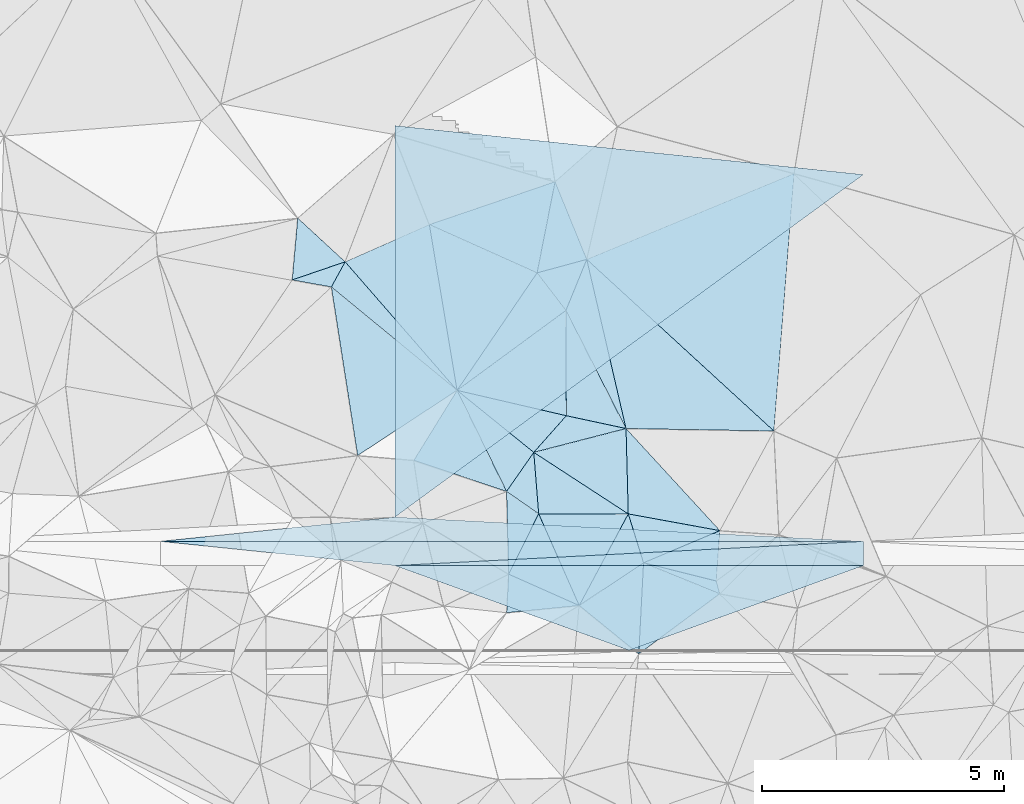
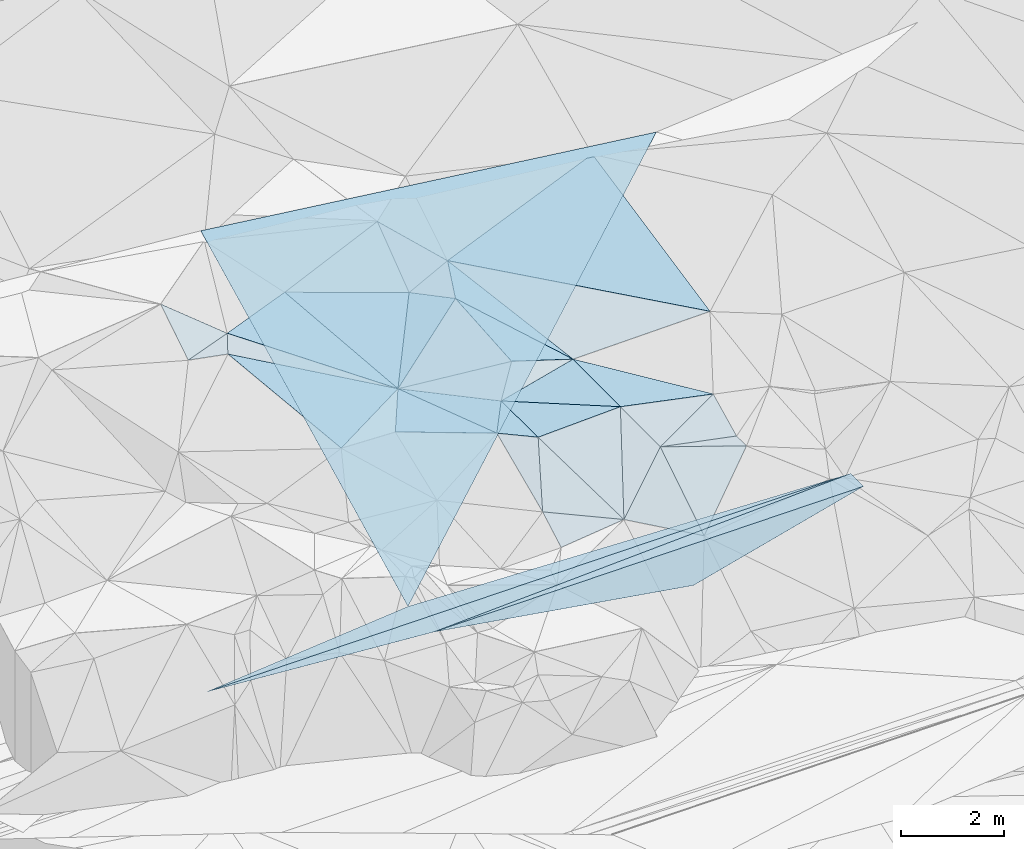
# One storey, part 69 of 275: 48 plates.
"""IFC2X3 building model written with IfcOpenShell, lengths in millimetres."""

from ifc_helpers import new_model, si_unit, frame, origin_with_axes, place, context, subcontext, project, spatial, polyline, outline, extrude, material, type_object, element, save


model = new_model("IFC2X3")

# Units and contexts
model_context = context("Model", 3, precision=1e-05, world=origin_with_axes())
body_context = subcontext(model_context, "Body", "Model", "MODEL_VIEW")
ifc_project = project(units=[si_unit("LENGTHUNIT", "METRE", prefix="MILLI"), si_unit("AREAUNIT", "SQUARE_METRE"), si_unit("VOLUMEUNIT", "CUBIC_METRE"), si_unit("MASSUNIT", "GRAM", prefix="KILO"), si_unit("TIMEUNIT", "SECOND"), si_unit("PLANEANGLEUNIT", "RADIAN"), si_unit("SOLIDANGLEUNIT", "STERADIAN"), si_unit("THERMODYNAMICTEMPERATUREUNIT", "DEGREE_CELSIUS"), si_unit("LUMINOUSINTENSITYUNIT", "LUMEN")], contexts=[model_context])

# Site, building, storey
site_placement = place(None, origin_with_axes())
site = spatial("IfcSite", under=ifc_project, at=site_placement, CompositionType="ELEMENT")
building_placement = place(site_placement, origin_with_axes())
building = spatial("IfcBuilding", under=site, at=building_placement, Name="Undefined", CompositionType="ELEMENT")
storey_placement = place(building_placement, origin_with_axes())
storey = spatial("IfcBuildingStorey", under=building, at=storey_placement, Name="Undefined", CompositionType="ELEMENT", Elevation=0.0)

# Plates
ifc_material = material()
plate_type_1 = type_object("IfcPlateType", PredefinedType="NOTDEFINED")
plate_1_placement = place(storey_placement, frame((-129444.335760061, 69294.3090173792, 48443.6810089496), z_axis=(0.00832550512650313, -4.76525014343269e-07, -0.999965342381505), x_axis=(0.998627967402267, -0.0517015939711349, 0.00831431914595258)))
element("IfcPlate", 1, at=plate_1_placement, inside=storey, type_object=plate_type_1, material=ifc_material, Name="00_PR", context=body_context, shape_type="SweptSolid", body=[
    extrude(outline(polyline([(0.0, 0.0), (9681.6103515625, -4.99348971061409e-08), (-4802.072265625, 748.999816894531), (0.0, 0.0)])), frame((-8.85201319254618e-08, 2.18876761149539e-07, -0.5000001331573), z_axis=(0.0, 0.0, 1.0), x_axis=(1.0, 0.0, 0.0)), (0.0, 0.0, 1.0), 1.0),
])
plate_2_placement = place(storey_placement, frame((-119776.008774443, 68793.7543278347, 48524.17701052), z_axis=(0.00832550512650313, -4.76525014343269e-07, -0.999965342381505), x_axis=(-5.72939716861899e-05, -0.9999999983587, -3.69036567042244e-11)))
element("IfcPlate", 2, at=plate_2_placement, inside=storey, type_object=plate_type_1, material=ifc_material, Name="00_PR", context=body_context, shape_type="SweptSolid", body=[
    extrude(outline(polyline([(0.0, 0.0), (500.0, 8.00355337560177e-10), (499.999267578125, 9668.6904296875), (0.0, 0.0)])), frame((-8.85201319254618e-08, 2.18876761149539e-07, -0.5000001331573), z_axis=(0.0, 0.0, 1.0), x_axis=(1.0, 0.0, 0.0)), (0.0, 0.0, 1.0), 1.0),
])
plate_3_placement = place(storey_placement, frame((-129444.393052582, 68294.3090073163, 48443.6810090413), z_axis=(0.00832550512650313, -4.76525014343269e-07, -0.999965342381505), x_axis=(-0.994653635901684, 0.102934762919728, -0.0082812541453832)))
element("IfcPlate", 3, at=plate_3_placement, inside=storey, type_object=plate_type_1, material=ifc_material, Name="00_PR", context=body_context, shape_type="SweptSolid", body=[
    extrude(outline(polyline([(0.0, 0.0), (4860.13330078125, -1.09284883365035e-08), (-9565.9501953125, 1492.03967285156), (0.0, 0.0)])), frame((-8.85201319254618e-08, 2.18876761149539e-07, -0.5000001331573), z_axis=(0.0, 0.0, 1.0), x_axis=(1.0, 0.0, 0.0)), (0.0, 0.0, 1.0), 1.0),
])
plate_4_placement = place(storey_placement, frame((-129444.335760061, 69294.3090173792, 48443.6810089496), z_axis=(0.00832550512650313, -4.76525014343269e-07, -0.999965342381505), x_axis=(0.998627967402267, -0.0517015939711349, 0.00831431914595258)))
element("IfcPlate", 4, at=plate_4_placement, inside=storey, type_object=plate_type_1, material=ifc_material, Name="00_PR", context=body_context, shape_type="SweptSolid", body=[
    extrude(outline(polyline([(0.0, 0.0), (9681.6103515625, -4.99348971061409e-08), (-4802.072265625, 748.999816894531), (0.0, 0.0)])), frame((-8.85201319254618e-08, 2.18876761149539e-07, -0.5000001331573), z_axis=(0.0, 0.0, 1.0), x_axis=(1.0, 0.0, 0.0)), (0.0, 0.0, 1.0), 1.0),
])
plate_5_placement = place(storey_placement, frame((-119776.008774443, 68793.7543278347, 48524.17701052), z_axis=(0.00832550512650313, -4.76525014343269e-07, -0.999965342381505), x_axis=(-5.72939716861899e-05, -0.9999999983587, -3.69036567042244e-11)))
element("IfcPlate", 5, at=plate_5_placement, inside=storey, type_object=plate_type_1, material=ifc_material, Name="00_PR", context=body_context, shape_type="SweptSolid", body=[
    extrude(outline(polyline([(0.0, 0.0), (500.0, 8.00355337560177e-10), (499.999267578125, 9668.6904296875), (0.0, 0.0)])), frame((-8.85201319254618e-08, 2.18876761149539e-07, -0.5000001331573), z_axis=(0.0, 0.0, 1.0), x_axis=(1.0, 0.0, 0.0)), (0.0, 0.0, 1.0), 1.0),
])
plate_6_placement = place(storey_placement, frame((-129444.393052582, 68294.3090073163, 48443.6810090413), z_axis=(0.00832550512650313, -4.76525014343269e-07, -0.999965342381505), x_axis=(-0.994653635901684, 0.102934762919728, -0.0082812541453832)))
element("IfcPlate", 6, at=plate_6_placement, inside=storey, type_object=plate_type_1, material=ifc_material, Name="00_PR", context=body_context, shape_type="SweptSolid", body=[
    extrude(outline(polyline([(0.0, 0.0), (4860.13330078125, -1.09284883365035e-08), (-9565.9501953125, 1492.03967285156), (0.0, 0.0)])), frame((-8.85201319254618e-08, 2.18876761149539e-07, -0.5000001331573), z_axis=(0.0, 0.0, 1.0), x_axis=(1.0, 0.0, 0.0)), (0.0, 0.0, 1.0), 1.0),
])
plate_7_placement = place(storey_placement, frame((-129444.335760061, 69294.3090173792, 48443.6810089496), z_axis=(0.00832550512650313, -4.76525014343269e-07, -0.999965342381505), x_axis=(0.998627967402267, -0.0517015939711349, 0.00831431914595258)))
element("IfcPlate", 7, at=plate_7_placement, inside=storey, type_object=plate_type_1, material=ifc_material, Name="00_PR", context=body_context, shape_type="SweptSolid", body=[
    extrude(outline(polyline([(0.0, 0.0), (9681.6103515625, -4.99348971061409e-08), (-4802.072265625, 748.999816894531), (0.0, 0.0)])), frame((-8.85201319254618e-08, 2.18876761149539e-07, -0.5000001331573), z_axis=(0.0, 0.0, 1.0), x_axis=(1.0, 0.0, 0.0)), (0.0, 0.0, 1.0), 1.0),
])
plate_8_placement = place(storey_placement, frame((-119776.008774443, 68793.7543278347, 48524.17701052), z_axis=(0.00832550512650313, -4.76525014343269e-07, -0.999965342381505), x_axis=(-5.72939716861899e-05, -0.9999999983587, -3.69036567042244e-11)))
element("IfcPlate", 8, at=plate_8_placement, inside=storey, type_object=plate_type_1, material=ifc_material, Name="00_PR", context=body_context, shape_type="SweptSolid", body=[
    extrude(outline(polyline([(0.0, 0.0), (500.0, 8.00355337560177e-10), (499.999267578125, 9668.6904296875), (0.0, 0.0)])), frame((-8.85201319254618e-08, 2.18876761149539e-07, -0.5000001331573), z_axis=(0.0, 0.0, 1.0), x_axis=(1.0, 0.0, 0.0)), (0.0, 0.0, 1.0), 1.0),
])
plate_9_placement = place(storey_placement, frame((-129444.393052582, 68294.3090073163, 48443.6810090413), z_axis=(0.00832550512650313, -4.76525014343269e-07, -0.999965342381505), x_axis=(-0.994653635901684, 0.102934762919728, -0.0082812541453832)))
element("IfcPlate", 9, at=plate_9_placement, inside=storey, type_object=plate_type_1, material=ifc_material, Name="00_PR", context=body_context, shape_type="SweptSolid", body=[
    extrude(outline(polyline([(0.0, 0.0), (4860.13330078125, -1.09284883365035e-08), (-9565.9501953125, 1492.03967285156), (0.0, 0.0)])), frame((-8.85201319254618e-08, 2.18876761149539e-07, -0.5000001331573), z_axis=(0.0, 0.0, 1.0), x_axis=(1.0, 0.0, 0.0)), (0.0, 0.0, 1.0), 1.0),
])
plate_type_2 = type_object("IfcPlateType", PredefinedType="NOTDEFINED")
plate_10_placement = place(storey_placement, frame((-124312.937117291, 68351.7391393524, 51019.5248388097), z_axis=(0.0515360907976266, 0.307029882947136, -0.950303468541901), x_axis=(0.907700275136061, 0.382399613268588, 0.172773685177903)))
element("IfcPlate", 10, at=plate_10_placement, inside=storey, type_object=plate_type_2, material=ifc_material, Name="00", context=body_context, shape_type="SweptSolid", body=[
    extrude(outline(polyline([(0.0, 0.0), (1736.37548828125, 5.82076609134674e-10), (1210.970703125, 962.314819335938), (0.0, 0.0)])), frame((-8.85201319254618e-08, 2.18876761149539e-07, -0.5000001331573), z_axis=(0.0, 0.0, 1.0), x_axis=(1.0, 0.0, 0.0)), (0.0, 0.0, 1.0), 1.0),
])
plate_type_3 = type_object("IfcPlateType", PredefinedType="NOTDEFINED")
plate_11_placement = place(storey_placement, frame((-126577.770346857, 70630.4646512945, 51519.5032296527), z_axis=(0.0431356535289658, 0.105349458426082, -0.993499273781295), x_axis=(0.83776809942243, -0.545603499068623, -0.0214810007728772)))
element("IfcPlate", 11, at=plate_11_placement, inside=storey, type_object=plate_type_3, material=ifc_material, Name="00", context=body_context, shape_type="SweptSolid", body=[
    extrude(outline(polyline([(0.0, 0.0), (2327.63818359375, -1.15605871542357e-08), (778.944030761719, 1013.18615722656), (0.0, 0.0)])), frame((-8.85201319254618e-08, 2.18876761149539e-07, -0.5000001331573), z_axis=(0.0, 0.0, 1.0), x_axis=(1.0, 0.0, 0.0)), (0.0, 0.0, 1.0), 1.0),
])
plate_type_4 = type_object("IfcPlateType", PredefinedType="NOTDEFINED")
plate_12_placement = place(storey_placement, frame((-124627.769831021, 69360.6483166408, 51469.5434608035), z_axis=(0.00196016810434817, 0.407870757378614, -0.91303756933458), x_axis=(0.980790077208936, -0.178878605876782, -0.0778027557871022)))
element("IfcPlate", 12, at=plate_12_placement, inside=storey, type_object=plate_type_4, material=ifc_material, Name="00", context=body_context, shape_type="SweptSolid", body=[
    extrude(outline(polyline([(0.0, 0.0), (1927.95227050781, -1.5352270565927e-08), (524.234985351563, 1022.04583740234), (0.0, 0.0)])), frame((-8.85201319254618e-08, 2.18876761149539e-07, -0.5000001331573), z_axis=(0.0, 0.0, 1.0), x_axis=(1.0, 0.0, 0.0)), (0.0, 0.0, 1.0), 1.0),
])
plate_type_5 = type_object("IfcPlateType", PredefinedType="NOTDEFINED")
plate_13_placement = place(storey_placement, frame((-124674.143238548, 71122.2047011062, 51549.5079593626), z_axis=(-0.158348949246532, 0.0809064240033333, -0.98406288458996), x_axis=(-0.963176777696257, 0.206672142717296, 0.171979999800261)))
element("IfcPlate", 13, at=plate_13_placement, inside=storey, type_object=plate_type_5, material=ifc_material, Name="00", context=body_context, shape_type="SweptSolid", body=[
    extrude(outline(polyline([(0.0, 0.0), (1279.21850585938, -7.45058059692383e-09), (1767.64172363281, 2123.87451171875), (0.0, 0.0)])), frame((-8.85201319254618e-08, 2.18876761149539e-07, -0.5000001331573), z_axis=(0.0, 0.0, 1.0), x_axis=(1.0, 0.0, 0.0)), (0.0, 0.0, 1.0), 1.0),
])
plate_type_6 = type_object("IfcPlateType", PredefinedType="NOTDEFINED")
plate_14_placement = place(storey_placement, frame((-124674.096315958, 71122.2290468685, 51549.5052579462), z_axis=(-0.0645017647531431, 0.129600696756393, -0.989466109446902), x_axis=(-0.449131033183579, 0.88166109684592, 0.144758506969021)))
element("IfcPlate", 14, at=plate_14_placement, inside=storey, type_object=plate_type_6, material=ifc_material, Name="00", context=body_context, shape_type="SweptSolid", body=[
    extrude(outline(polyline([(0.0, 0.0), (2763.22265625, -2.52039171755314e-08), (3515.13452148438, 862.107055664063), (0.0, 0.0)])), frame((-8.85201319254618e-08, 2.18876761149539e-07, -0.5000001331573), z_axis=(0.0, 0.0, 1.0), x_axis=(1.0, 0.0, 0.0)), (0.0, 0.0, 1.0), 1.0),
])
plate_type_7 = type_object("IfcPlateType", PredefinedType="NOTDEFINED")
plate_15_placement = place(storey_placement, frame((-127139.727185454, 69824.5325130001, 51439.5665744181), z_axis=(0.239030809457038, 0.437609843361658, -0.866811338829447), x_axis=(0.819368744523016, -0.569928124129053, -0.0617802057743058)))
element("IfcPlate", 15, at=plate_15_placement, inside=storey, type_object=plate_type_7, material=ifc_material, Name="00", context=body_context, shape_type="SweptSolid", body=[
    extrude(outline(polyline([(0.0, 0.0), (809.320678710938, 2.80488166026771e-09), (1062.24890136719, 1585.25305175781), (0.0, 0.0)])), frame((-8.85201319254618e-08, 2.18876761149539e-07, -0.5000001331573), z_axis=(0.0, 0.0, 1.0), x_axis=(1.0, 0.0, 0.0)), (0.0, 0.0, 1.0), 1.0),
])
plate_type_8 = type_object("IfcPlateType", PredefinedType="NOTDEFINED")
for number, where, z_axis, x_axis, name in (
    (16, (-129444.39318017, 68294.1877470874, 48443.6959361818), (0.00806306952558709, -0.242528174049018, -0.970110855367713), (0.999965340787191, -5.73519775278889e-05, 0.0083254990906575), "00_PR"),
    (17, (-129444.39318017, 68294.1877470874, 48443.6959361818), (0.00806306952558709, -0.242528174049018, -0.970110855367713), (0.999965340787191, -5.73519775278889e-05, 0.0083254990906575), "00_PR"),
    (18, (-129444.39318017, 68294.1877470874, 48443.6959361818), (0.00806306952558709, -0.242528174049018, -0.970110855367713), (0.999965340787191, -5.73519775278889e-05, 0.0083254990906575), "00_PR"),
):
    element("IfcPlate", number, at=place(storey_placement, frame(where, z_axis=z_axis, x_axis=x_axis)), inside=storey, type_object=plate_type_8, material=ifc_material, Name=name, context=body_context, shape_type="SweptSolid", body=[
        extrude(outline(polyline([(0.0, 0.0), (9668.6904296875, -3.96539689972997e-09), (4837.9873046875, 1803.85485839844), (0.0, 0.0)])), frame((-8.85201319254618e-08, 2.18876761149539e-07, -0.5000001331573), z_axis=(0.0, 0.0, 1.0), x_axis=(1.0, 0.0, 0.0)), (0.0, 0.0, 1.0), 1.0),
    ])
plate_type_9 = type_object("IfcPlateType", PredefinedType="NOTDEFINED")
for number, where, z_axis, x_axis, name in (
    (19, (-129444.336182528, 69294.53261692, 48443.733790464), (0.00747221277555471, 0.447200796920443, -0.894402377719311), (5.12609174268665e-05, 0.894427213806252, 0.447213546949446), "00_PR"),
    (20, (-129444.336182528, 69294.53261692, 48443.733790464), (0.00747221277555471, 0.447200796920443, -0.894402377719311), (5.12609174268665e-05, 0.894427213806252, 0.447213546949446), "00_PR"),
    (21, (-129444.336182528, 69294.53261692, 48443.733790464), (0.00747221277555471, 0.447200796920443, -0.894402377719311), (5.12609174268665e-05, 0.894427213806252, 0.447213546949446), "00_PR"),
):
    element("IfcPlate", number, at=place(storey_placement, frame(where, z_axis=z_axis, x_axis=x_axis)), inside=storey, type_object=plate_type_9, material=ifc_material, Name=name, context=body_context, shape_type="SweptSolid", body=[
        extrude(outline(polyline([(0.0, 0.0), (9030.6259765625, 4.51982486993074e-08), (7938.47216796875, 9668.623046875), (0.0, 0.0)])), frame((-8.85201319254618e-08, 2.18876761149539e-07, -0.5000001331573), z_axis=(0.0, 0.0, 1.0), x_axis=(1.0, 0.0, 0.0)), (0.0, 0.0, 1.0), 1.0),
    ])
plate_type_10 = type_object("IfcPlateType", PredefinedType="NOTDEFINED")
plate_16_placement = place(storey_placement, frame((-128160.253068707, 71909.8952778772, 51589.5072815032), z_axis=(-0.0291699102488049, 0.167773082117906, -0.985393986815799), x_axis=(-0.765830912353817, 0.629785394063295, 0.129897540807591)))
element("IfcPlate", 22, at=plate_16_placement, inside=storey, type_object=plate_type_10, material=ifc_material, Name="00", context=body_context, shape_type="SweptSolid", body=[
    extrude(outline(polyline([(0.0, 0.0), (3387.28515625, -1.40862539410591e-08), (3506.99755859375, 585.293884277344), (0.0, 0.0)])), frame((-8.85201319254618e-08, 2.18876761149539e-07, -0.5000001331573), z_axis=(0.0, 0.0, 1.0), x_axis=(1.0, 0.0, 0.0)), (0.0, 0.0, 1.0), 1.0),
])
plate_type_11 = type_object("IfcPlateType", PredefinedType="NOTDEFINED")
plate_17_placement = place(storey_placement, frame((-125906.11466732, 71386.6474831464, 51769.5150823467), z_axis=(0.125918911407506, 0.208806652836142, -0.969816585484758), x_axis=(-0.644681218496998, -0.725808764752047, -0.239974505992477)))
element("IfcPlate", 23, at=plate_17_placement, inside=storey, type_object=plate_type_11, material=ifc_material, Name="00", context=body_context, shape_type="SweptSolid", body=[
    extrude(outline(polyline([(0.0, 0.0), (1041.77734375, -4.86033968627453e-09), (1116.55334472656, 2034.77478027344), (0.0, 0.0)])), frame((-8.85201319254618e-08, 2.18876761149539e-07, -0.5000001331573), z_axis=(0.0, 0.0, 1.0), x_axis=(1.0, 0.0, 0.0)), (0.0, 0.0, 1.0), 1.0),
])
plate_type_12 = type_object("IfcPlateType", PredefinedType="NOTDEFINED")
plate_18_placement = place(storey_placement, frame((-124674.099632621, 71122.1859397391, 51549.5017295349), z_axis=(-0.0711384885321428, 0.0433829312007016, -0.996522572112543), x_axis=(0.674719800359606, -0.733713797086432, -0.0801077709570257)))
element("IfcPlate", 24, at=plate_18_placement, inside=storey, type_object=plate_type_12, material=ifc_material, Name="00", context=body_context, shape_type="SweptSolid", body=[
    extrude(outline(polyline([(0.0, 0.0), (2871.13208007813, -8.49831849336624e-09), (1330.24182128906, 1158.73071289063), (0.0, 0.0)])), frame((-8.85201319254618e-08, 2.18876761149539e-07, -0.5000001331573), z_axis=(0.0, 0.0, 1.0), x_axis=(1.0, 0.0, 0.0)), (0.0, 0.0, 1.0), 1.0),
])
plate_type_13 = type_object("IfcPlateType", PredefinedType="NOTDEFINED")
plate_19_placement = place(storey_placement, frame((-126509.590636603, 74334.3753728813, 51829.511725589), z_axis=(0.0171571075948877, 0.214691930279505, -0.97653110996621), x_axis=(-0.910029584673822, 0.407939743608207, 0.0736974938736797)))
element("IfcPlate", 25, at=plate_19_placement, inside=storey, type_object=plate_type_13, material=ifc_material, Name="00", context=body_context, shape_type="SweptSolid", body=[
    extrude(outline(polyline([(0.0, 0.0), (2442.41674804688, -6.71934685669839e-09), (460.322723388672, 1907.72192382813), (0.0, 0.0)])), frame((-8.85201319254618e-08, 2.18876761149539e-07, -0.5000001331573), z_axis=(0.0, 0.0, 1.0), x_axis=(1.0, 0.0, 0.0)), (0.0, 0.0, 1.0), 1.0),
])
plate_type_14 = type_object("IfcPlateType", PredefinedType="NOTDEFINED")
plate_20_placement = place(storey_placement, frame((-125484.459065814, 74612.4986336358, 52059.5117680325), z_axis=(0.215310766088622, 0.0139528963210471, -0.976445897472351), x_axis=(-0.376371330773425, -0.921465191023686, -0.0961588430854013)))
element("IfcPlate", 26, at=plate_20_placement, inside=storey, type_object=plate_type_14, material=ifc_material, Name="00", context=body_context, shape_type="SweptSolid", body=[
    extrude(outline(polyline([(0.0, 0.0), (1143.94055175781, -6.19911588728428e-09), (664.282775878906, 860.074645996094), (0.0, 0.0)])), frame((-8.85201319254618e-08, 2.18876761149539e-07, -0.5000001331573), z_axis=(0.0, 0.0, 1.0), x_axis=(1.0, 0.0, 0.0)), (0.0, 0.0, 1.0), 1.0),
])
plate_type_15 = type_object("IfcPlateType", PredefinedType="NOTDEFINED")
plate_21_placement = place(storey_placement, frame((-128732.284714729, 75330.6855391924, 52009.5036333081), z_axis=(-0.0278441221793931, 0.117227145086736, -0.992714712953763), x_axis=(0.910029584672226, -0.407939743615816, -0.0736974938512678)))
element("IfcPlate", 27, at=plate_21_placement, inside=storey, type_object=plate_type_15, material=ifc_material, Name="00", context=body_context, shape_type="SweptSolid", body=[
    extrude(outline(polyline([(0.0, 0.0), (2442.41674804688, -6.71934685669839e-09), (1947.005859375, 2900.82202148438), (0.0, 0.0)])), frame((-8.85201319254618e-08, 2.18876761149539e-07, -0.5000001331573), z_axis=(0.0, 0.0, 1.0), x_axis=(1.0, 0.0, 0.0)), (0.0, 0.0, 1.0), 1.0),
])
plate_type_16 = type_object("IfcPlateType", PredefinedType="NOTDEFINED")
plate_22_placement = place(storey_placement, frame((-126509.512899734, 74334.2580059223, 51829.5075990406), z_axis=(0.172624933979639, -0.0200430092784232, -0.984783686881332), x_axis=(0.603671381061534, -0.78786575078458, 0.121854103040937)))
element("IfcPlate", 28, at=plate_22_placement, inside=storey, type_object=plate_type_16, material=ifc_material, Name="00", context=body_context, shape_type="SweptSolid", body=[
    extrude(outline(polyline([(0.0, 0.0), (984.784240722656, 2.3719621822238e-09), (884.457702636719, 2806.76586914063), (0.0, 0.0)])), frame((-8.85201319254618e-08, 2.18876761149539e-07, -0.5000001331573), z_axis=(0.0, 0.0, 1.0), x_axis=(1.0, 0.0, 0.0)), (0.0, 0.0, 1.0), 1.0),
])
plate_type_17 = type_object("IfcPlateType", PredefinedType="NOTDEFINED")
plate_23_placement = place(storey_placement, frame((-125484.482911818, 74612.583275618, 52059.5156543824), z_axis=(0.167618304717028, 0.183236464774474, -0.968673578611878), x_axis=(-0.943219310951893, -0.256017153191473, -0.211642502156749)))
element("IfcPlate", 29, at=plate_23_placement, inside=storey, type_object=plate_type_17, material=ifc_material, Name="00", context=body_context, shape_type="SweptSolid", body=[
    extrude(outline(polyline([(0.0, 0.0), (1086.73828125, -3.60887497663498e-09), (166.18537902832, 1733.17126464844), (0.0, 0.0)])), frame((-8.85201319254618e-08, 2.18876761149539e-07, -0.5000001331573), z_axis=(0.0, 0.0, 1.0), x_axis=(1.0, 0.0, 0.0)), (0.0, 0.0, 1.0), 1.0),
])
plate_type_18 = type_object("IfcPlateType", PredefinedType="NOTDEFINED")
plate_24_placement = place(storey_placement, frame((-130470.039681607, 74562.4583520311, 52109.5073777564), z_axis=(-0.0305692352336442, 0.168513181109903, -0.985225268478966), x_axis=(-0.475889516684769, -0.869250811869576, -0.133911142081678)))
element("IfcPlate", 30, at=plate_24_placement, inside=storey, type_object=plate_type_18, material=ifc_material, Name="00", context=body_context, shape_type="SweptSolid", body=[
    extrude(outline(polyline([(0.0, 0.0), (597.411071777344, 9.02218744158745e-10), (848.494445800781, 783.235046386719), (0.0, 0.0)])), frame((-8.85201319254618e-08, 2.18876761149539e-07, -0.5000001331573), z_axis=(0.0, 0.0, 1.0), x_axis=(1.0, 0.0, 0.0)), (0.0, 0.0, 1.0), 1.0),
])
plate_type_19 = type_object("IfcPlateType", PredefinedType="NOTDEFINED")
plate_25_placement = place(storey_placement, frame((-128160.289971644, 71909.8634927573, 51589.5053878427), z_axis=(-0.103003117376694, 0.104228086520023, -0.989205167693264), x_axis=(-0.649636935468019, 0.746044338194318, 0.146252171005843)))
element("IfcPlate", 31, at=plate_25_placement, inside=storey, type_object=plate_type_19, material=ifc_material, Name="00", context=body_context, shape_type="SweptSolid", body=[
    extrude(outline(polyline([(0.0, 0.0), (3555.50268554688, -2.61934474110603e-10), (2985.11938476563, 1815.12060546875), (0.0, 0.0)])), frame((-8.85201319254618e-08, 2.18876761149539e-07, -0.5000001331573), z_axis=(0.0, 0.0, 1.0), x_axis=(1.0, 0.0, 0.0)), (0.0, 0.0, 1.0), 1.0),
])
plate_type_20 = type_object("IfcPlateType", PredefinedType="NOTDEFINED")
plate_26_placement = place(storey_placement, frame((-125484.549269869, 74612.5678734776, 52059.5061415135), z_axis=(0.0349038995462965, 0.152425780563923, -0.987698384738955), x_axis=(0.734787691241913, -0.673795562951014, -0.0780165889212418)))
element("IfcPlate", 32, at=plate_26_placement, inside=storey, type_object=plate_type_20, material=ifc_material, Name="00", context=body_context, shape_type="SweptSolid", body=[
    extrude(outline(polyline([(0.0, 0.0), (5255.29248046875, 1.54250301420689e-09), (2987.10302734375, 2043.67700195313), (0.0, 0.0)])), frame((-8.85201319254618e-08, 2.18876761149539e-07, -0.5000001331573), z_axis=(0.0, 0.0, 1.0), x_axis=(1.0, 0.0, 0.0)), (0.0, 0.0, 1.0), 1.0),
])
plate_type_21 = type_object("IfcPlateType", PredefinedType="NOTDEFINED")
plate_27_placement = place(storey_placement, frame((-128160.189288347, 71909.8526794387, 51589.5041323601), z_axis=(0.0983688185785236, 0.0825969353639885, -0.9917163514836), x_axis=(0.79938710098981, 0.586984022240562, 0.128179641150223)))
element("IfcPlate", 33, at=plate_27_placement, inside=storey, type_object=plate_type_21, material=ifc_material, Name="00", context=body_context, shape_type="SweptSolid", body=[
    extrude(outline(polyline([(0.0, 0.0), (2808.55834960938, 4.22005541622639e-09), (1517.78930664063, 1755.93725585938), (0.0, 0.0)])), frame((-8.85201319254618e-08, 2.18876761149539e-07, -0.5000001331573), z_axis=(0.0, 0.0, 1.0), x_axis=(1.0, 0.0, 0.0)), (0.0, 0.0, 1.0), 1.0),
])
plate_type_22 = type_object("IfcPlateType", PredefinedType="NOTDEFINED")
plate_28_placement = place(storey_placement, frame((-124627.678850877, 69360.6682368191, 51469.5624499197), z_axis=(0.18392075138497, 0.447710223799097, -0.875059262402125), x_axis=(0.274067416293419, -0.878298467227122, -0.391763772945812)))
element("IfcPlate", 34, at=plate_28_placement, inside=storey, type_object=plate_type_22, material=ifc_material, Name="00", context=body_context, shape_type="SweptSolid", body=[
    extrude(outline(polyline([(0.0, 0.0), (1148.6513671875, 6.70843292027712e-09), (1845.46850585938, 1607.8388671875), (0.0, 0.0)])), frame((-8.85201319254618e-08, 2.18876761149539e-07, -0.5000001331573), z_axis=(0.0, 0.0, 1.0), x_axis=(1.0, 0.0, 0.0)), (0.0, 0.0, 1.0), 1.0),
])
plate_type_23 = type_object("IfcPlateType", PredefinedType="NOTDEFINED")
plate_29_placement = place(storey_placement, frame((-127139.928103688, 69824.3093440483, 51439.5066819399), z_axis=(-0.16282695406165, -0.00870528426547676, -0.986616237985602), x_axis=(-0.937111533132133, 0.314250180826264, 0.151884160864141)))
element("IfcPlate", 35, at=plate_29_placement, inside=storey, type_object=plate_type_23, material=ifc_material, Name="00", context=body_context, shape_type="SweptSolid", body=[
    extrude(outline(polyline([(0.0, 0.0), (2041.02917480469, 3.92901711165905e-10), (1634.37158203125, 1655.84704589844), (0.0, 0.0)])), frame((-8.85201319254618e-08, 2.18876761149539e-07, -0.5000001331573), z_axis=(0.0, 0.0, 1.0), x_axis=(1.0, 0.0, 0.0)), (0.0, 0.0, 1.0), 1.0),
])
plate_type_24 = type_object("IfcPlateType", PredefinedType="NOTDEFINED")
plate_30_placement = place(storey_placement, frame((-124312.86346822, 68351.8005856713, 51019.5596411327), z_axis=(0.198848138389257, 0.429918114413626, -0.880698491402227), x_axis=(-0.0466255647396249, -0.893476500963589, -0.446683107961979)))
element("IfcPlate", 36, at=plate_30_placement, inside=storey, type_object=plate_type_24, material=ifc_material, Name="00", context=body_context, shape_type="SweptSolid", body=[
    extrude(outline(polyline([(0.0, 0.0), (2104.40014648438, -5.99538907408714e-09), (1175.77453613281, 1299.32836914063), (0.0, 0.0)])), frame((-8.85201319254618e-08, 2.18876761149539e-07, -0.5000001331573), z_axis=(0.0, 0.0, 1.0), x_axis=(1.0, 0.0, 0.0)), (0.0, 0.0, 1.0), 1.0),
])
plate_type_25 = type_object("IfcPlateType", PredefinedType="NOTDEFINED")
plate_31_placement = place(storey_placement, frame((-125639.704464554, 67470.079476413, 50289.5716482258), z_axis=(0.0377944702853066, 0.51445538830071, -0.856683857361757), x_axis=(-0.357059849358534, 0.807653437198135, 0.469259192086953)))
element("IfcPlate", 37, at=plate_31_placement, inside=storey, type_object=plate_type_25, material=ifc_material, Name="00", context=body_context, shape_type="SweptSolid", body=[
    extrude(outline(polyline([(0.0, 0.0), (2344.12036132813, 5.28234522789717e-09), (1719.36572265625, 1742.03381347656), (0.0, 0.0)])), frame((-8.85201319254618e-08, 2.18876761149539e-07, -0.5000001331573), z_axis=(0.0, 0.0, 1.0), x_axis=(1.0, 0.0, 0.0)), (0.0, 0.0, 1.0), 1.0),
])
plate_type_26 = type_object("IfcPlateType", PredefinedType="NOTDEFINED")
plate_32_placement = place(storey_placement, frame((-125639.728061667, 67470.0239295865, 50289.5424937118), z_axis=(-0.00940434962731324, 0.403359259971004, -0.914993369158341), x_axis=(-0.994583370710727, -0.0984975721621415, -0.0331985991248532)))
element("IfcPlate", 38, at=plate_32_placement, inside=storey, type_object=plate_type_26, material=ifc_material, Name="00", context=body_context, shape_type="SweptSolid", body=[
    extrude(outline(polyline([(0.0, 0.0), (1506.08764648438, -9.47329681366682e-09), (1374.22277832031, 859.541564941406), (0.0, 0.0)])), frame((-8.85201319254618e-08, 2.18876761149539e-07, -0.5000001331573), z_axis=(0.0, 0.0, 1.0), x_axis=(1.0, 0.0, 0.0)), (0.0, 0.0, 1.0), 1.0),
])
plate_type_27 = type_object("IfcPlateType", PredefinedType="NOTDEFINED")
plate_33_placement = place(storey_placement, frame((-125639.695784536, 67470.0821134894, 50289.5737149662), z_axis=(0.0551494904319287, 0.519726576297547, -0.852550772444157), x_axis=(-0.89811818175778, 0.398908550682777, 0.18508295380252)))
element("IfcPlate", 39, at=plate_33_placement, inside=storey, type_object=plate_type_27, material=ifc_material, Name="00", context=body_context, shape_type="SweptSolid", body=[
    extrude(outline(polyline([(0.0, 0.0), (1620.89477539063, 1.03755155578256e-08), (1710.53662109375, 1602.79895019531), (0.0, 0.0)])), frame((-8.85201319254618e-08, 2.18876761149539e-07, -0.5000001331573), z_axis=(0.0, 0.0, 1.0), x_axis=(1.0, 0.0, 0.0)), (0.0, 0.0, 1.0), 1.0),
])
plate_type_28 = type_object("IfcPlateType", PredefinedType="NOTDEFINED")
plate_34_placement = place(storey_placement, frame((-126476.716741679, 69363.1099262778, 51389.5025761941), z_axis=(-0.00426663974668798, 0.10170290795756, -0.994805666599386), x_axis=(-0.81936874450674, 0.569928124150549, 0.0617802057918558)))
element("IfcPlate", 40, at=plate_34_placement, inside=storey, type_object=plate_type_28, material=ifc_material, Name="00", context=body_context, shape_type="SweptSolid", body=[
    extrude(outline(polyline([(0.0, 0.0), (809.320678710938, 2.80488166026771e-09), (813.151062011719, 985.94384765625), (0.0, 0.0)])), frame((-8.85201319254618e-08, 2.18876761149539e-07, -0.5000001331573), z_axis=(0.0, 0.0, 1.0), x_axis=(1.0, 0.0, 0.0)), (0.0, 0.0, 1.0), 1.0),
])
plate_type_29 = type_object("IfcPlateType", PredefinedType="NOTDEFINED")
plate_35_placement = place(storey_placement, frame((-126577.833571738, 70630.6013530408, 51519.5391089396), z_axis=(-0.0833107236721403, 0.378754000601803, -0.921740055736624), x_axis=(0.644681218495602, 0.725808764771421, 0.239974505937633)))
element("IfcPlate", 41, at=plate_35_placement, inside=storey, type_object=plate_type_29, material=ifc_material, Name="00", context=body_context, shape_type="SweptSolid", body=[
    extrude(outline(polyline([(0.0, 0.0), (1041.77734375, -4.86033968627453e-09), (1591.41491699219, 1155.11840820313), (0.0, 0.0)])), frame((-8.85201319254618e-08, 2.18876761149539e-07, -0.5000001331573), z_axis=(0.0, 0.0, 1.0), x_axis=(1.0, 0.0, 0.0)), (0.0, 0.0, 1.0), 1.0),
])
plate_type_30 = type_object("IfcPlateType", PredefinedType="NOTDEFINED")
plate_36_placement = place(storey_placement, frame((-122740.393185776, 67713.0757466875, 50879.5368782438), z_axis=(0.0681494927495851, 0.370812297544373, -0.926204019980392), x_axis=(-0.92336104286304, 0.375028926756048, 0.082205161754511)))
element("IfcPlate", 42, at=plate_36_placement, inside=storey, type_object=plate_type_30, material=ifc_material, Name="00", context=body_context, shape_type="SweptSolid", body=[
    extrude(outline(polyline([(0.0, 0.0), (1703.05603027344, 1.11758708953857e-08), (173.922637939453, 232.918258666992), (0.0, 0.0)])), frame((-8.85201319254618e-08, 2.18876761149539e-07, -0.5000001331573), z_axis=(0.0, 0.0, 1.0), x_axis=(1.0, 0.0, 0.0)), (0.0, 0.0, 1.0), 1.0),
])
plate_type_31 = type_object("IfcPlateType", PredefinedType="NOTDEFINED")
plate_37_placement = place(storey_placement, frame((-124674.062075264, 71122.1869952493, 51549.5005006576), z_axis=(0.00399731452394022, 0.0454678831176902, -0.998957803453876), x_axis=(0.0262412221789323, -0.99862654437044, -0.0453478019016324)))
element("IfcPlate", 43, at=plate_37_placement, inside=storey, type_object=plate_type_31, material=ifc_material, Name="00", context=body_context, shape_type="SweptSolid", body=[
    extrude(outline(polyline([(0.0, 0.0), (1764.14282226563, 1.18889147415757e-08), (442.481170654297, 1916.01416015625), (0.0, 0.0)])), frame((-8.85201319254618e-08, 2.18876761149539e-07, -0.5000001331573), z_axis=(0.0, 0.0, 1.0), x_axis=(1.0, 0.0, 0.0)), (0.0, 0.0, 1.0), 1.0),
])
plate_type_32 = type_object("IfcPlateType", PredefinedType="NOTDEFINED")
plate_38_placement = place(storey_placement, frame((-124411.031934811, 66471.5739387037, 50079.5539449967), z_axis=(0.0996070620613658, 0.440782179449412, -0.892070346703291), x_axis=(0.0466255647522301, 0.893476501000209, 0.446683107887413)))
element("IfcPlate", 44, at=plate_38_placement, inside=storey, type_object=plate_type_32, material=ifc_material, Name="00", context=body_context, shape_type="SweptSolid", body=[
    extrude(outline(polyline([(0.0, 0.0), (2104.40014648438, -5.99538907408714e-09), (1544.52563476563, 1608.39685058594), (0.0, 0.0)])), frame((-8.85201319254618e-08, 2.18876761149539e-07, -0.5000001331573), z_axis=(0.0, 0.0, 1.0), x_axis=(1.0, 0.0, 0.0)), (0.0, 0.0, 1.0), 1.0),
])
plate_type_33 = type_object("IfcPlateType", PredefinedType="NOTDEFINED")
plate_39_placement = place(storey_placement, frame((-130211.903798156, 70565.494308142, 51709.5042407657), z_axis=(-0.106851791556606, 0.0745647135767748, -0.991475061779346), x_axis=(-0.153493640163071, 0.983992617783902, 0.090544080846146)))
element("IfcPlate", 45, at=plate_39_placement, inside=storey, type_object=plate_type_33, material=ifc_material, Name="00", context=body_context, shape_type="SweptSolid", body=[
    extrude(outline(polyline([(0.0, 0.0), (3534.19018554688, -1.53086148202419e-08), (997.060119628906, 2244.2529296875), (0.0, 0.0)])), frame((-8.85201319254618e-08, 2.18876761149539e-07, -0.5000001331573), z_axis=(0.0, 0.0, 1.0), x_axis=(1.0, 0.0, 0.0)), (0.0, 0.0, 1.0), 1.0),
])
plate_type_34 = type_object("IfcPlateType", PredefinedType="NOTDEFINED")
plate_40_placement = place(storey_placement, frame((-128160.227014299, 71909.8528345423, 51589.5018310954), z_axis=(0.0229382553617892, 0.0828820426441626, -0.99629533946922), x_axis=(0.777176470114635, -0.628342934847054, -0.034378634759785)))
element("IfcPlate", 46, at=plate_40_placement, inside=storey, type_object=plate_type_34, material=ifc_material, Name="00", context=body_context, shape_type="SweptSolid", body=[
    extrude(outline(polyline([(0.0, 0.0), (2036.14831542969, 3.63797880709171e-09), (2108.58911132813, 983.286499023438), (0.0, 0.0)])), frame((-8.85201319254618e-08, 2.18876761149539e-07, -0.5000001331573), z_axis=(0.0, 0.0, 1.0), x_axis=(1.0, 0.0, 0.0)), (0.0, 0.0, 1.0), 1.0),
])
plate_type_35 = type_object("IfcPlateType", PredefinedType="NOTDEFINED")
plate_41_placement = place(storey_placement, frame((-121623.062103501, 71071.5351083324, 51649.5016839936), z_axis=(-0.0393306433623675, 0.0725013329157226, -0.996592523159865), x_axis=(-0.734787691240638, 0.67379556296892, 0.0780165887785987)))
element("IfcPlate", 47, at=plate_41_placement, inside=storey, type_object=plate_type_35, material=ifc_material, Name="00", context=body_context, shape_type="SweptSolid", body=[
    extrude(outline(polyline([(0.0, 0.0), (5255.29248046875, 1.54250301420689e-09), (3301.56689453125, 4199.23291015625), (0.0, 0.0)])), frame((-8.85201319254618e-08, 2.18876761149539e-07, -0.5000001331573), z_axis=(0.0, 0.0, 1.0), x_axis=(1.0, 0.0, 0.0)), (0.0, 0.0, 1.0), 1.0),
])
plate_type_36 = type_object("IfcPlateType", PredefinedType="NOTDEFINED")
plate_42_placement = place(storey_placement, frame((-130470.077418875, 74562.5659285943, 52109.5412856271), z_axis=(-0.105999592902685, 0.383626633967781, -0.917384702300521), x_axis=(-0.945877525924097, -0.323482209204211, -0.0259801131651231)))
element("IfcPlate", 48, at=plate_42_placement, inside=storey, type_object=plate_type_36, material=ifc_material, Name="00", context=body_context, shape_type="SweptSolid", body=[
    extrude(outline(polyline([(0.0, 0.0), (1154.72937011719, 4.51109372079372e-10), (620.75146484375, 1274.38916015625), (0.0, 0.0)])), frame((-8.85201319254618e-08, 2.18876761149539e-07, -0.5000001331573), z_axis=(0.0, 0.0, 1.0), x_axis=(1.0, 0.0, 0.0)), (0.0, 0.0, 1.0), 1.0),
])

save(model, "model.ifc")
